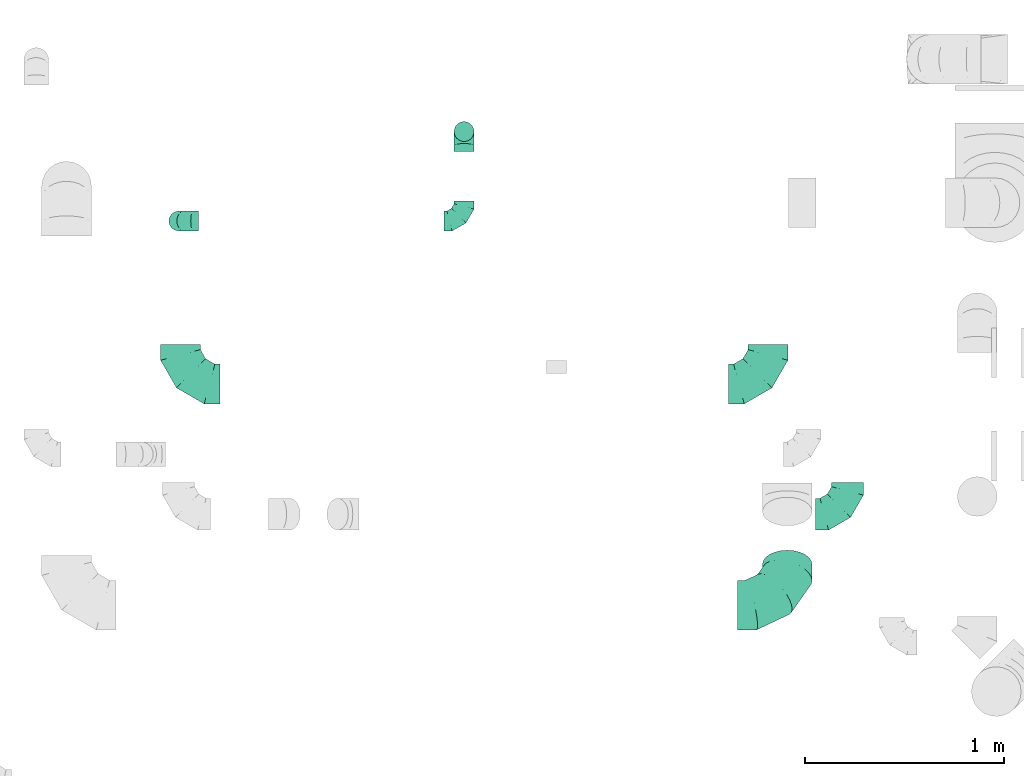
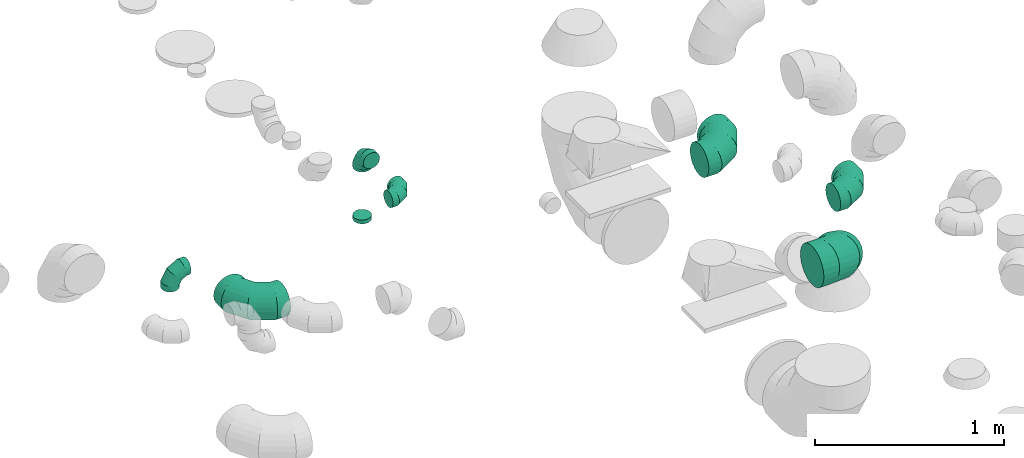
# One storey, part 42 of 59: 8 flow fittings.
"""IFC2X3 building model written with IfcOpenShell, lengths in millimetres."""

from ifc_helpers import new_model, entity, si_unit, converted_unit, derived_unit, direction, frame, origin, origin_2d_with_axis, place, context, subcontext, project, spatial, circle, extrude, faceted_brep, source, transform, mapped, material, type_object, type_shapes, element, save


model = new_model("IFC2X3")

# Units and contexts
model_context = context("Model", 3, precision=0.01, world=origin(), true_north=direction((6.12303176911189e-17, 1.0)))
body_context = subcontext(model_context, "Body", "Model", "MODEL_VIEW")
ifc_project = project(units=[si_unit("LENGTHUNIT", "METRE", prefix="MILLI"), si_unit("AREAUNIT", "SQUARE_METRE"), si_unit("VOLUMEUNIT", "CUBIC_METRE"), converted_unit("PLANEANGLEUNIT", "DEGREE", entity("IfcRatioMeasure", 0.0174532925199433), si_unit("PLANEANGLEUNIT", "RADIAN"), dimensions=[0, 0, 0, 0, 0, 0, 0]), si_unit("MASSUNIT", "GRAM", prefix="KILO"), derived_unit("MASSDENSITYUNIT", [(si_unit("MASSUNIT", "GRAM", prefix="KILO"), 1), (si_unit("LENGTHUNIT", "METRE"), -3)]), derived_unit("MOMENTOFINERTIAUNIT", [(si_unit("LENGTHUNIT", "METRE"), 4)]), si_unit("TIMEUNIT", "SECOND"), si_unit("FREQUENCYUNIT", "HERTZ"), si_unit("THERMODYNAMICTEMPERATUREUNIT", "DEGREE_CELSIUS"), derived_unit("THERMALTRANSMITTANCEUNIT", [(si_unit("MASSUNIT", "GRAM", prefix="KILO"), 1), (si_unit("THERMODYNAMICTEMPERATUREUNIT", "KELVIN"), -1), (si_unit("TIMEUNIT", "SECOND"), -3)]), derived_unit("VOLUMETRICFLOWRATEUNIT", [(si_unit("LENGTHUNIT", "METRE"), 3), (si_unit("TIMEUNIT", "SECOND"), -1)]), derived_unit("MASSFLOWRATEUNIT", [(si_unit("MASSUNIT", "GRAM", prefix="KILO"), 1), (si_unit("TIMEUNIT", "SECOND"), -1)]), derived_unit("ROTATIONALFREQUENCYUNIT", [(si_unit("TIMEUNIT", "SECOND"), -1)]), si_unit("ELECTRICCURRENTUNIT", "AMPERE"), si_unit("ELECTRICVOLTAGEUNIT", "VOLT"), si_unit("POWERUNIT", "WATT"), si_unit("FORCEUNIT", "NEWTON", prefix="KILO"), si_unit("ILLUMINANCEUNIT", "LUX"), si_unit("LUMINOUSFLUXUNIT", "LUMEN"), si_unit("LUMINOUSINTENSITYUNIT", "CANDELA"), derived_unit("USERDEFINED", [(si_unit("MASSUNIT", "GRAM", prefix="KILO"), -1), (si_unit("LENGTHUNIT", "METRE"), -2), (si_unit("TIMEUNIT", "SECOND"), 3), (si_unit("LUMINOUSFLUXUNIT", "LUMEN"), 1)]), derived_unit("LINEARVELOCITYUNIT", [(si_unit("LENGTHUNIT", "METRE"), 1), (si_unit("TIMEUNIT", "SECOND"), -1)]), si_unit("PRESSUREUNIT", "PASCAL"), derived_unit("USERDEFINED", [(si_unit("LENGTHUNIT", "METRE"), -2), (si_unit("MASSUNIT", "GRAM", prefix="KILO"), 1), (si_unit("TIMEUNIT", "SECOND"), -2)]), derived_unit("LINEARFORCEUNIT", [(si_unit("MASSUNIT", "GRAM", prefix="KILO"), 1), (si_unit("LENGTHUNIT", "METRE"), 1), (si_unit("TIMEUNIT", "SECOND"), -2), (si_unit("LENGTHUNIT", "METRE"), -1)]), derived_unit("PLANARFORCEUNIT", [(si_unit("MASSUNIT", "GRAM", prefix="KILO"), 1), (si_unit("LENGTHUNIT", "METRE"), 1), (si_unit("TIMEUNIT", "SECOND"), -2), (si_unit("LENGTHUNIT", "METRE"), -2)])], contexts=[model_context])

# Site, building, storey
site_placement = place(None, origin())
site = spatial("IfcSite", under=ifc_project, at=site_placement, CompositionType="ELEMENT")
building_placement = place(site_placement, origin())
building = spatial("IfcBuilding", under=site, at=building_placement, CompositionType="ELEMENT")
storey_placement = place(building_placement, frame((0.0, 0.0, 28200.0)))
storey = spatial("IfcBuildingStorey", under=building, at=storey_placement, CompositionType="ELEMENT", Elevation=28200.0)

# Flow fittings
ifc_material = material()
duct_fitting_type_1 = type_object("IfcDuctFittingType", PredefinedType="NOTDEFINED", material=ifc_material)
shared_shape_1 = source(origin(), body_context, "Body", "SweptSolid", [
    extrude(circle(Radius=49.9999999999997, at=origin_2d_with_axis()), frame((0.0, 0.0, 0.0), z_axis=(1.0, 0.0, 0.0), x_axis=(0.0, 1.0, 0.0)), (0.0, 0.0, 1.0), 25.0000000000018),
])
type_shapes(duct_fitting_type_1, [shared_shape_1])
flow_fitting_1_placement = place(storey_placement, frame((70040.54, 11618.54, 2740.0), z_axis=(0.0, -1.0, 0.0), x_axis=(0.0, 0.0, -1.0)))
element("IfcFlowFitting", 1, at=flow_fitting_1_placement, inside=storey, type_object=duct_fitting_type_1, material=ifc_material, context=body_context, shape_type="MappedRepresentation", body=[
    mapped(shared_shape_1, transform((0.0, 0.0, 0.0), scale=1.0)),
])
duct_fitting_type_2 = type_object("IfcDuctFittingType", PredefinedType="NOTDEFINED", material=ifc_material)
shared_shape_2 = source(origin(), body_context, "Body", "Brep", [
    faceted_brep([(-160.0, 0.0, -80.0), (-160.0, -20.71, -77.27), (-160.0, -40.0, -69.28), (-160.0, -56.57, -56.57), (-160.0, -69.28, -40.0), (-160.0, -77.27, -20.71), (-160.0, -80.0, 0.0), (-160.0, -77.27, 20.71), (-160.0, -69.28, 40.0), (-160.0, -56.57, 56.57), (-160.0, -40.0, 69.28), (-160.0, -20.71, 77.27), (-160.0, 0.0, 80.0), (-160.0, 20.71, 77.27), (-160.0, 40.0, 69.28), (-160.0, 56.57, 56.57), (-160.0, 69.28, 40.0), (-160.0, 77.27, 20.71), (-160.0, 80.0, 0.0), (-160.0, 77.27, -20.71), (-160.0, 69.28, -40.0), (-160.0, 56.57, -56.57), (-160.0, 40.0, -69.28), (-160.0, 20.71, -77.27), (-122.68, 20.71, 77.27), (-127.85, 40.0, 69.28), (-117.13, 0.0, 80.0), (-132.29, 56.57, 56.57), (-137.83, 77.27, 20.71), (-138.56, 80.0, 0.0), (-135.69, 69.28, 40.0), (-135.69, 69.28, -40.0), (-132.29, 56.57, -56.57), (-137.83, 77.27, -20.71), (-122.68, 20.71, -77.27), (-117.13, 0.0, -80.0), (-127.85, 40.0, -69.28), (-111.58, -20.71, -77.27), (-106.41, -40.0, -69.28), (-101.97, -56.57, -56.57), (-98.56, -69.28, -40.0), (-96.42, -77.27, -20.71), (-95.69, -80.0, 0.0), (-96.42, -77.27, 20.71), (-98.56, -69.28, 40.0), (-101.97, -56.57, 56.57), (-106.41, -40.0, 69.28), (-111.58, -20.71, 77.27), (-58.03, 58.03, 77.27), (-72.15, 72.15, 69.28), (-42.87, 42.87, 80.0), (-84.28, 84.28, 56.57), (-93.59, 93.59, 40.0), (-99.44, 99.44, 20.71), (-101.44, 101.44, 0.0), (-99.44, 99.44, -20.71), (-93.59, 93.59, -40.0), (-84.28, 84.28, -56.57), (-58.03, 58.03, -77.27), (-42.87, 42.87, -80.0), (-72.15, 72.15, -69.28), (-27.71, 27.71, -77.27), (-13.59, 13.59, -69.28), (-1.46, 1.46, -56.57), (7.85, -7.85, -40.0), (13.7, -13.7, -20.71), (15.69, -15.69, 0.0), (13.7, -13.7, 20.71), (7.85, -7.85, 40.0), (-1.46, 1.46, 56.57), (-13.59, 13.59, 69.28), (-27.71, 27.71, 77.27), (-20.71, 122.68, 77.27), (-40.0, 127.85, 69.28), (0.0, 117.13, 80.0), (-56.57, 132.29, 56.57), (-69.28, 135.69, 40.0), (-77.27, 137.83, 20.71), (-80.0, 138.56, 0.0), (-77.27, 137.83, -20.71), (-69.28, 135.69, -40.0), (-56.57, 132.29, -56.57), (-20.71, 122.68, -77.27), (0.0, 117.13, -80.0), (-40.0, 127.85, -69.28), (20.71, 111.58, -77.27), (40.0, 106.41, -69.28), (56.57, 101.97, -56.57), (69.28, 98.56, -40.0), (77.27, 96.42, -20.71), (80.0, 95.69, 0.0), (77.27, 96.42, 20.71), (69.28, 98.56, 40.0), (56.57, 101.97, 56.57), (40.0, 106.41, 69.28), (20.71, 111.58, 77.27), (-20.71, 160.0, -77.27), (-40.0, 160.0, -69.28), (-56.57, 160.0, -56.57), (-69.28, 160.0, -40.0), (-77.27, 160.0, -20.71), (-80.0, 160.0, 0.0), (-77.27, 160.0, 20.71), (-69.28, 160.0, 40.0), (-56.57, 160.0, 56.57), (-40.0, 160.0, 69.28), (-20.71, 160.0, 77.27), (0.0, 160.0, 80.0), (20.71, 160.0, 77.27), (40.0, 160.0, 69.28), (56.57, 160.0, 56.57), (69.28, 160.0, 40.0), (77.27, 160.0, 20.71), (80.0, 160.0, 0.0), (77.27, 160.0, -20.71), (69.28, 160.0, -40.0), (56.57, 160.0, -56.57), (40.0, 160.0, -69.28), (20.71, 160.0, -77.27), (0.0, 160.0, -80.0)], [[[0, 1, 2, 3, 4, 5, 6, 7, 8, 9, 10, 11, 12, 13, 14, 15, 16, 17, 18, 19, 20, 21, 22, 23]], [[24, 25, 14, 13]], [[26, 24, 13, 12]], [[14, 25, 27, 15]], [[28, 29, 18, 17]], [[30, 28, 17, 16]], [[15, 27, 30, 16]], [[20, 31, 32, 21]], [[33, 31, 20, 19]], [[18, 29, 33, 19]], [[34, 35, 0, 23]], [[36, 34, 23, 22]], [[32, 36, 22, 21]], [[1, 0, 35, 37]], [[2, 1, 37, 38]], [[3, 2, 38, 39]], [[5, 4, 40, 41]], [[6, 5, 41, 42]], [[39, 40, 4, 3]], [[6, 42, 43, 7]], [[7, 43, 44, 8]], [[8, 44, 45, 9]], [[9, 45, 46, 10]], [[10, 46, 47, 11]], [[26, 12, 11, 47]], [[48, 49, 25, 24]], [[50, 48, 24, 26]], [[27, 25, 49, 51]], [[52, 53, 28, 30]], [[51, 52, 30, 27]], [[29, 28, 53, 54]], [[55, 56, 31, 33]], [[54, 55, 33, 29]], [[32, 31, 56, 57]], [[58, 59, 35, 34]], [[60, 58, 34, 36]], [[57, 60, 36, 32]], [[37, 35, 59, 61]], [[38, 37, 61, 62]], [[39, 38, 62, 63]], [[41, 40, 64, 65]], [[42, 41, 65, 66]], [[63, 64, 40, 39]], [[43, 42, 66, 67]], [[44, 43, 67, 68]], [[68, 69, 45, 44]], [[46, 45, 69, 70]], [[47, 46, 70, 71]], [[26, 47, 71, 50]], [[72, 73, 49, 48]], [[74, 72, 48, 50]], [[51, 49, 73, 75]], [[76, 77, 53, 52]], [[75, 76, 52, 51]], [[54, 53, 77, 78]], [[79, 80, 56, 55]], [[78, 79, 55, 54]], [[57, 56, 80, 81]], [[82, 83, 59, 58]], [[84, 82, 58, 60]], [[81, 84, 60, 57]], [[61, 59, 83, 85]], [[62, 61, 85, 86]], [[63, 62, 86, 87]], [[65, 64, 88, 89]], [[66, 65, 89, 90]], [[87, 88, 64, 63]], [[67, 66, 90, 91]], [[68, 67, 91, 92]], [[92, 93, 69, 68]], [[70, 69, 93, 94]], [[71, 70, 94, 95]], [[50, 71, 95, 74]], [[96, 97, 98, 99, 100, 101, 102, 103, 104, 105, 106, 107, 108, 109, 110, 111, 112, 113, 114, 115, 116, 117, 118, 119]], [[72, 74, 107, 106]], [[73, 72, 106, 105]], [[75, 73, 105, 104]], [[77, 76, 103, 102]], [[78, 77, 102, 101]], [[75, 104, 103, 76]], [[78, 101, 100, 79]], [[79, 100, 99, 80]], [[80, 99, 98, 81]], [[84, 97, 96, 82]], [[82, 96, 119, 83]], [[84, 81, 98, 97]], [[118, 117, 86, 85]], [[119, 118, 85, 83]], [[116, 87, 86, 117]], [[88, 115, 114, 89]], [[89, 114, 113, 90]], [[115, 88, 87, 116]], [[112, 111, 92, 91]], [[113, 112, 91, 90]], [[111, 110, 93, 92]], [[95, 94, 109, 108]], [[74, 95, 108, 107]], [[110, 109, 94, 93]]]),
])
type_shapes(duct_fitting_type_2, [shared_shape_2])
flow_fitting_2_placement = place(storey_placement, frame((71970.11, 9693.42, 3400.0)))
element("IfcFlowFitting", 2, at=flow_fitting_2_placement, inside=storey, type_object=duct_fitting_type_2, material=ifc_material, context=body_context, shape_type="MappedRepresentation", body=[
    mapped(shared_shape_2, transform((0.0, 0.0, 0.0), scale=1.0)),
])
duct_fitting_type_3 = type_object("IfcDuctFittingType", PredefinedType="NOTDEFINED", material=ifc_material)
shared_shape_3 = source(origin(), body_context, "Body", "Brep", [
    faceted_brep([(-100.0, 0.0, -50.0), (-100.0, -12.94, -48.3), (-100.0, -25.0, -43.3), (-100.0, -35.36, -35.36), (-100.0, -43.3, -25.0), (-100.0, -48.3, -12.94), (-100.0, -50.0, 0.0), (-100.0, -48.3, 12.94), (-100.0, -43.3, 25.0), (-100.0, -35.36, 35.36), (-100.0, -25.0, 43.3), (-100.0, -12.94, 48.3), (-100.0, 0.0, 50.0), (-100.0, 12.94, 48.3), (-100.0, 25.0, 43.3), (-100.0, 35.36, 35.36), (-100.0, 43.3, 25.0), (-100.0, 48.3, 12.94), (-100.0, 50.0, 0.0), (-100.0, 48.3, -12.94), (-100.0, 43.3, -25.0), (-100.0, 35.36, -35.36), (-100.0, 25.0, -43.3), (-100.0, 12.94, -48.3), (-76.67, 12.94, 48.3), (-79.9, 25.0, 43.3), (-73.21, 0.0, 50.0), (-82.68, 35.36, 35.36), (-86.15, 48.3, 12.94), (-86.6, 50.0, 0.0), (-84.81, 43.3, 25.0), (-84.81, 43.3, -25.0), (-82.68, 35.36, -35.36), (-86.15, 48.3, -12.94), (-76.67, 12.94, -48.3), (-73.21, 0.0, -50.0), (-79.9, 25.0, -43.3), (-69.74, -12.94, -48.3), (-66.51, -25.0, -43.3), (-63.73, -35.36, -35.36), (-61.6, -43.3, -25.0), (-60.26, -48.3, -12.94), (-59.81, -50.0, 0.0), (-60.26, -48.3, 12.94), (-61.6, -43.3, 25.0), (-63.73, -35.36, 35.36), (-66.51, -25.0, 43.3), (-69.74, -12.94, 48.3), (-36.27, 36.27, 48.3), (-45.1, 45.1, 43.3), (-26.79, 26.79, 50.0), (-52.68, 52.68, 35.36), (-58.49, 58.49, 25.0), (-62.15, 62.15, 12.94), (-63.4, 63.4, 0.0), (-62.15, 62.15, -12.94), (-58.49, 58.49, -25.0), (-52.68, 52.68, -35.36), (-36.27, 36.27, -48.3), (-26.79, 26.79, -50.0), (-45.1, 45.1, -43.3), (-17.32, 17.32, -48.3), (-8.49, 8.49, -43.3), (-0.91, 0.91, -35.36), (4.9, -4.9, -25.0), (8.56, -8.56, -12.94), (9.81, -9.81, 0.0), (8.56, -8.56, 12.94), (4.9, -4.9, 25.0), (-0.91, 0.91, 35.36), (-8.49, 8.49, 43.3), (-17.32, 17.32, 48.3), (-12.94, 76.67, 48.3), (-25.0, 79.9, 43.3), (0.0, 73.21, 50.0), (-35.36, 82.68, 35.36), (-43.3, 84.81, 25.0), (-48.3, 86.15, 12.94), (-50.0, 86.6, 0.0), (-48.3, 86.15, -12.94), (-43.3, 84.81, -25.0), (-35.36, 82.68, -35.36), (-12.94, 76.67, -48.3), (0.0, 73.21, -50.0), (-25.0, 79.9, -43.3), (12.94, 69.74, -48.3), (25.0, 66.51, -43.3), (35.36, 63.73, -35.36), (43.3, 61.6, -25.0), (48.3, 60.26, -12.94), (50.0, 59.81, 0.0), (48.3, 60.26, 12.94), (43.3, 61.6, 25.0), (35.36, 63.73, 35.36), (25.0, 66.51, 43.3), (12.94, 69.74, 48.3), (-12.94, 100.0, -48.3), (-25.0, 100.0, -43.3), (-35.36, 100.0, -35.36), (-43.3, 100.0, -25.0), (-48.3, 100.0, -12.94), (-50.0, 100.0, 0.0), (-48.3, 100.0, 12.94), (-43.3, 100.0, 25.0), (-35.36, 100.0, 35.36), (-25.0, 100.0, 43.3), (-12.94, 100.0, 48.3), (0.0, 100.0, 50.0), (12.94, 100.0, 48.3), (25.0, 100.0, 43.3), (35.36, 100.0, 35.36), (43.3, 100.0, 25.0), (48.3, 100.0, 12.94), (50.0, 100.0, 0.0), (48.3, 100.0, -12.94), (43.3, 100.0, -25.0), (35.36, 100.0, -35.36), (25.0, 100.0, -43.3), (12.94, 100.0, -48.3), (0.0, 100.0, -50.0)], [[[0, 1, 2, 3, 4, 5, 6, 7, 8, 9, 10, 11, 12, 13, 14, 15, 16, 17, 18, 19, 20, 21, 22, 23]], [[24, 25, 14, 13]], [[26, 24, 13, 12]], [[14, 25, 27, 15]], [[28, 29, 18, 17]], [[30, 28, 17, 16]], [[15, 27, 30, 16]], [[20, 31, 32, 21]], [[33, 31, 20, 19]], [[18, 29, 33, 19]], [[34, 35, 0, 23]], [[36, 34, 23, 22]], [[32, 36, 22, 21]], [[2, 1, 37, 38]], [[3, 2, 38, 39]], [[0, 35, 37, 1]], [[5, 4, 40, 41]], [[6, 5, 41, 42]], [[3, 39, 40, 4]], [[6, 42, 43, 7]], [[7, 43, 44, 8]], [[8, 44, 45, 9]], [[10, 46, 47, 11]], [[11, 47, 26, 12]], [[10, 9, 45, 46]], [[48, 49, 25, 24]], [[50, 48, 24, 26]], [[27, 25, 49, 51]], [[52, 53, 28, 30]], [[51, 52, 30, 27]], [[29, 28, 53, 54]], [[55, 56, 31, 33]], [[54, 55, 33, 29]], [[57, 32, 31, 56]], [[58, 59, 35, 34]], [[60, 58, 34, 36]], [[57, 60, 36, 32]], [[37, 35, 59, 61]], [[38, 37, 61, 62]], [[39, 38, 62, 63]], [[41, 40, 64, 65]], [[42, 41, 65, 66]], [[63, 64, 40, 39]], [[43, 42, 66, 67]], [[44, 43, 67, 68]], [[68, 69, 45, 44]], [[46, 45, 69, 70]], [[47, 46, 70, 71]], [[26, 47, 71, 50]], [[72, 73, 49, 48]], [[74, 72, 48, 50]], [[51, 49, 73, 75]], [[76, 77, 53, 52]], [[75, 76, 52, 51]], [[54, 53, 77, 78]], [[79, 80, 56, 55]], [[78, 79, 55, 54]], [[81, 57, 56, 80]], [[82, 83, 59, 58]], [[84, 82, 58, 60]], [[81, 84, 60, 57]], [[61, 59, 83, 85]], [[62, 61, 85, 86]], [[63, 62, 86, 87]], [[65, 64, 88, 89]], [[66, 65, 89, 90]], [[87, 88, 64, 63]], [[67, 66, 90, 91]], [[68, 67, 91, 92]], [[92, 93, 69, 68]], [[70, 69, 93, 94]], [[71, 70, 94, 95]], [[50, 71, 95, 74]], [[96, 97, 98, 99, 100, 101, 102, 103, 104, 105, 106, 107, 108, 109, 110, 111, 112, 113, 114, 115, 116, 117, 118, 119]], [[72, 74, 107, 106]], [[73, 72, 106, 105]], [[75, 73, 105, 104]], [[77, 76, 103, 102]], [[78, 77, 102, 101]], [[75, 104, 103, 76]], [[78, 101, 100, 79]], [[79, 100, 99, 80]], [[80, 99, 98, 81]], [[96, 119, 83, 82]], [[97, 96, 82, 84]], [[84, 81, 98, 97]], [[83, 119, 118, 85]], [[85, 118, 117, 86]], [[86, 117, 116, 87]], [[88, 115, 114, 89]], [[89, 114, 113, 90]], [[87, 116, 115, 88]], [[91, 90, 113, 112]], [[92, 91, 112, 111]], [[93, 92, 111, 110]], [[95, 94, 109, 108]], [[74, 95, 108, 107]], [[110, 109, 94, 93]]]),
])
type_shapes(duct_fitting_type_3, [shared_shape_3])
flow_fitting_3_placement = place(storey_placement, frame((70040.54, 11168.54, 3150.0)))
element("IfcFlowFitting", 3, at=flow_fitting_3_placement, inside=storey, type_object=duct_fitting_type_3, material=ifc_material, context=body_context, shape_type="MappedRepresentation", body=[
    mapped(shared_shape_3, transform((0.0, 0.0, 0.0), scale=1.0)),
])
for number, where, z_axis, x_axis in (
    (4, (70040.54, 11618.54, 3150.0), (-1.0, 0.0, 0.0), (0.0, 1.0, 0.0)),
    (5, (68605.54, 11168.54, 3150.0), (0.0, -1.0, 0.0), (-1.0, 0.0, 0.0)),
):
    element("IfcFlowFitting", number, at=place(storey_placement, frame(where, z_axis=z_axis, x_axis=x_axis)), inside=storey, type_object=duct_fitting_type_3, material=ifc_material, context=body_context, shape_type="MappedRepresentation", body=[
        mapped(shared_shape_3, transform((0.0, 0.0, 0.0), scale=1.0)),
    ])
duct_fitting_type_4 = type_object("IfcDuctFittingType", PredefinedType="NOTDEFINED", material=ifc_material)
shared_shape_4 = source(origin(), body_context, "Body", "Brep", [
    faceted_brep([(-250.0, 0.0, -125.0), (-250.0, -32.35, -120.74), (-250.0, -62.5, -108.25), (-250.0, -88.39, -88.39), (-250.0, -108.25, -62.5), (-250.0, -120.74, -32.35), (-250.0, -125.0, 0.0), (-250.0, -120.74, 32.35), (-250.0, -108.25, 62.5), (-250.0, -88.39, 88.39), (-250.0, -62.5, 108.25), (-250.0, -32.35, 120.74), (-250.0, 0.0, 125.0), (-250.0, 32.35, 120.74), (-250.0, 62.5, 108.25), (-250.0, 88.39, 88.39), (-250.0, 108.25, 62.5), (-250.0, 120.74, 32.35), (-250.0, 125.0, 0.0), (-250.0, 120.74, -32.35), (-250.0, 108.25, -62.5), (-250.0, 88.39, -88.39), (-250.0, 62.5, -108.25), (-250.0, 32.35, -120.74), (-191.68, 32.35, 120.74), (-199.76, 62.5, 108.25), (-183.01, 0.0, 125.0), (-206.7, 88.39, 88.39), (-215.37, 120.74, 32.35), (-216.51, 125.0, 0.0), (-212.02, 108.25, 62.5), (-212.02, 108.25, -62.5), (-206.7, 88.39, -88.39), (-215.37, 120.74, -32.35), (-191.68, 32.35, -120.74), (-183.01, 0.0, -125.0), (-199.76, 62.5, -108.25), (-174.34, -32.35, -120.74), (-166.27, -62.5, -108.25), (-159.33, -88.39, -88.39), (-154.01, -108.25, -62.5), (-150.66, -120.74, -32.35), (-149.52, -125.0, 0.0), (-150.66, -120.74, 32.35), (-154.01, -108.25, 62.5), (-159.33, -88.39, 88.39), (-166.27, -62.5, 108.25), (-174.34, -32.35, 120.74), (-90.67, 90.67, 120.74), (-112.74, 112.74, 108.25), (-66.99, 66.99, 125.0), (-131.69, 131.69, 88.39), (-146.23, 146.23, 62.5), (-155.38, 155.38, 32.35), (-158.49, 158.49, 0.0), (-155.38, 155.38, -32.35), (-146.23, 146.23, -62.5), (-131.69, 131.69, -88.39), (-90.67, 90.67, -120.74), (-66.99, 66.99, -125.0), (-112.74, 112.74, -108.25), (-43.3, 43.3, -120.74), (-21.23, 21.23, -108.25), (-2.28, 2.28, -88.39), (12.26, -12.26, -62.5), (21.4, -21.4, -32.35), (24.52, -24.52, 0.0), (21.4, -21.4, 32.35), (12.26, -12.26, 62.5), (-2.28, 2.28, 88.39), (-21.23, 21.23, 108.25), (-43.3, 43.3, 120.74), (-32.35, 191.68, 120.74), (-62.5, 199.76, 108.25), (0.0, 183.01, 125.0), (-88.39, 206.7, 88.39), (-108.25, 212.02, 62.5), (-120.74, 215.37, 32.35), (-125.0, 216.51, 0.0), (-120.74, 215.37, -32.35), (-108.25, 212.02, -62.5), (-88.39, 206.7, -88.39), (-32.35, 191.68, -120.74), (0.0, 183.01, -125.0), (-62.5, 199.76, -108.25), (32.35, 174.34, -120.74), (62.5, 166.27, -108.25), (88.39, 159.33, -88.39), (108.25, 154.01, -62.5), (120.74, 150.66, -32.35), (125.0, 149.52, 0.0), (120.74, 150.66, 32.35), (108.25, 154.01, 62.5), (88.39, 159.33, 88.39), (62.5, 166.27, 108.25), (32.35, 174.34, 120.74), (-32.35, 250.0, -120.74), (-62.5, 250.0, -108.25), (-88.39, 250.0, -88.39), (-108.25, 250.0, -62.5), (-120.74, 250.0, -32.35), (-125.0, 250.0, 0.0), (-120.74, 250.0, 32.35), (-108.25, 250.0, 62.5), (-88.39, 250.0, 88.39), (-62.5, 250.0, 108.25), (-32.35, 250.0, 120.74), (0.0, 250.0, 125.0), (32.35, 250.0, 120.74), (62.5, 250.0, 108.25), (88.39, 250.0, 88.39), (108.25, 250.0, 62.5), (120.74, 250.0, 32.35), (125.0, 250.0, 0.0), (120.74, 250.0, -32.35), (108.25, 250.0, -62.5), (88.39, 250.0, -88.39), (62.5, 250.0, -108.25), (32.35, 250.0, -120.74), (0.0, 250.0, -125.0)], [[[0, 1, 2, 3, 4, 5, 6, 7, 8, 9, 10, 11, 12, 13, 14, 15, 16, 17, 18, 19, 20, 21, 22, 23]], [[24, 25, 14, 13]], [[26, 24, 13, 12]], [[14, 25, 27, 15]], [[28, 29, 18, 17]], [[30, 28, 17, 16]], [[15, 27, 30, 16]], [[20, 31, 32, 21]], [[33, 31, 20, 19]], [[18, 29, 33, 19]], [[34, 35, 0, 23]], [[36, 34, 23, 22]], [[21, 32, 36, 22]], [[1, 0, 35, 37]], [[2, 1, 37, 38]], [[38, 39, 3, 2]], [[5, 4, 40, 41]], [[6, 5, 41, 42]], [[39, 40, 4, 3]], [[6, 42, 43, 7]], [[7, 43, 44, 8]], [[8, 44, 45, 9]], [[9, 45, 46, 10]], [[10, 46, 47, 11]], [[26, 12, 11, 47]], [[48, 49, 25, 24]], [[50, 48, 24, 26]], [[27, 25, 49, 51]], [[52, 53, 28, 30]], [[51, 52, 30, 27]], [[29, 28, 53, 54]], [[55, 56, 31, 33]], [[54, 55, 33, 29]], [[32, 31, 56, 57]], [[58, 59, 35, 34]], [[60, 58, 34, 36]], [[57, 60, 36, 32]], [[37, 35, 59, 61]], [[38, 37, 61, 62]], [[39, 38, 62, 63]], [[41, 40, 64, 65]], [[42, 41, 65, 66]], [[63, 64, 40, 39]], [[43, 42, 66, 67]], [[44, 43, 67, 68]], [[68, 69, 45, 44]], [[46, 45, 69, 70]], [[47, 46, 70, 71]], [[26, 47, 71, 50]], [[72, 73, 49, 48]], [[74, 72, 48, 50]], [[51, 49, 73, 75]], [[76, 77, 53, 52]], [[75, 76, 52, 51]], [[54, 53, 77, 78]], [[79, 80, 56, 55]], [[78, 79, 55, 54]], [[57, 56, 80, 81]], [[82, 83, 59, 58]], [[84, 82, 58, 60]], [[81, 84, 60, 57]], [[61, 59, 83, 85]], [[62, 61, 85, 86]], [[63, 62, 86, 87]], [[65, 64, 88, 89]], [[66, 65, 89, 90]], [[87, 88, 64, 63]], [[67, 66, 90, 91]], [[68, 67, 91, 92]], [[92, 93, 69, 68]], [[70, 69, 93, 94]], [[71, 70, 94, 95]], [[50, 71, 95, 74]], [[96, 97, 98, 99, 100, 101, 102, 103, 104, 105, 106, 107, 108, 109, 110, 111, 112, 113, 114, 115, 116, 117, 118, 119]], [[72, 74, 107, 106]], [[73, 72, 106, 105]], [[75, 73, 105, 104]], [[77, 76, 103, 102]], [[78, 77, 102, 101]], [[75, 104, 103, 76]], [[78, 101, 100, 79]], [[79, 100, 99, 80]], [[80, 99, 98, 81]], [[84, 97, 96, 82]], [[82, 96, 119, 83]], [[84, 81, 98, 97]], [[83, 119, 118, 85]], [[85, 118, 117, 86]], [[116, 87, 86, 117]], [[88, 115, 114, 89]], [[89, 114, 113, 90]], [[115, 88, 87, 116]], [[91, 90, 113, 112]], [[92, 91, 112, 111]], [[111, 110, 93, 92]], [[95, 94, 109, 108]], [[74, 95, 108, 107]], [[110, 109, 94, 93]]]),
])
type_shapes(duct_fitting_type_4, [shared_shape_4])
flow_fitting_4_placement = place(storey_placement, frame((71666.81, 9235.86, 3375.0), z_axis=(0.0, 0.573576436351062, 0.81915204428898), x_axis=(1.0, 0.0, 0.0)))
element("IfcFlowFitting", 6, at=flow_fitting_4_placement, inside=storey, type_object=duct_fitting_type_4, material=ifc_material, context=body_context, shape_type="MappedRepresentation", body=[
    mapped(shared_shape_4, transform((0.0, 0.0, 0.0), scale=1.0)),
])
duct_fitting_type_5 = type_object("IfcDuctFittingType", PredefinedType="NOTDEFINED", material=ifc_material)
shared_shape_5 = source(origin(), body_context, "Body", "Brep", [
    faceted_brep([(-200.0, 0.0, -100.0), (-200.0, -25.88, -96.59), (-200.0, -50.0, -86.6), (-200.0, -70.71, -70.71), (-200.0, -86.6, -50.0), (-200.0, -96.59, -25.88), (-200.0, -100.0, 0.0), (-200.0, -96.59, 25.88), (-200.0, -86.6, 50.0), (-200.0, -70.71, 70.71), (-200.0, -50.0, 86.6), (-200.0, -25.88, 96.59), (-200.0, 0.0, 100.0), (-200.0, 25.88, 96.59), (-200.0, 50.0, 86.6), (-200.0, 70.71, 70.71), (-200.0, 86.6, 50.0), (-200.0, 96.59, 25.88), (-200.0, 100.0, 0.0), (-200.0, 96.59, -25.88), (-200.0, 86.6, -50.0), (-200.0, 70.71, -70.71), (-200.0, 50.0, -86.6), (-200.0, 25.88, -96.59), (-153.35, 25.88, 96.59), (-159.81, 50.0, 86.6), (-146.41, 0.0, 100.0), (-165.36, 70.71, 70.71), (-172.29, 96.59, 25.88), (-173.21, 100.0, 0.0), (-169.62, 86.6, 50.0), (-169.62, 86.6, -50.0), (-165.36, 70.71, -70.71), (-172.29, 96.59, -25.88), (-153.35, 25.88, -96.59), (-146.41, 0.0, -100.0), (-159.81, 50.0, -86.6), (-139.48, -25.88, -96.59), (-133.01, -50.0, -86.6), (-127.46, -70.71, -70.71), (-123.21, -86.6, -50.0), (-120.53, -96.59, -25.88), (-119.62, -100.0, 0.0), (-120.53, -96.59, 25.88), (-123.21, -86.6, 50.0), (-127.46, -70.71, 70.71), (-133.01, -50.0, 86.6), (-139.48, -25.88, 96.59), (-72.54, 72.54, 96.59), (-90.19, 90.19, 86.6), (-53.59, 53.59, 100.0), (-105.35, 105.35, 70.71), (-116.99, 116.99, 50.0), (-124.3, 124.3, 25.88), (-126.79, 126.79, 0.0), (-124.3, 124.3, -25.88), (-116.99, 116.99, -50.0), (-105.35, 105.35, -70.71), (-72.54, 72.54, -96.59), (-53.59, 53.59, -100.0), (-90.19, 90.19, -86.6), (-34.64, 34.64, -96.59), (-16.99, 16.99, -86.6), (-1.83, 1.83, -70.71), (9.81, -9.81, -50.0), (17.12, -17.12, -25.88), (19.62, -19.62, 0.0), (17.12, -17.12, 25.88), (9.81, -9.81, 50.0), (-1.83, 1.83, 70.71), (-16.99, 16.99, 86.6), (-34.64, 34.64, 96.59), (-25.88, 153.35, 96.59), (-50.0, 159.81, 86.6), (0.0, 146.41, 100.0), (-70.71, 165.36, 70.71), (-86.6, 169.62, 50.0), (-96.59, 172.29, 25.88), (-100.0, 173.21, 0.0), (-96.59, 172.29, -25.88), (-86.6, 169.62, -50.0), (-70.71, 165.36, -70.71), (-25.88, 153.35, -96.59), (0.0, 146.41, -100.0), (-50.0, 159.81, -86.6), (25.88, 139.48, -96.59), (50.0, 133.01, -86.6), (70.71, 127.46, -70.71), (86.6, 123.21, -50.0), (96.59, 120.53, -25.88), (100.0, 119.62, 0.0), (96.59, 120.53, 25.88), (86.6, 123.21, 50.0), (70.71, 127.46, 70.71), (50.0, 133.01, 86.6), (25.88, 139.48, 96.59), (-25.88, 200.0, -96.59), (-50.0, 200.0, -86.6), (-70.71, 200.0, -70.71), (-86.6, 200.0, -50.0), (-96.59, 200.0, -25.88), (-100.0, 200.0, 0.0), (-96.59, 200.0, 25.88), (-86.6, 200.0, 50.0), (-70.71, 200.0, 70.71), (-50.0, 200.0, 86.6), (-25.88, 200.0, 96.59), (0.0, 200.0, 100.0), (25.88, 200.0, 96.59), (50.0, 200.0, 86.6), (70.71, 200.0, 70.71), (86.6, 200.0, 50.0), (96.59, 200.0, 25.88), (100.0, 200.0, 0.0), (96.59, 200.0, -25.88), (86.6, 200.0, -50.0), (70.71, 200.0, -70.71), (50.0, 200.0, -86.6), (25.88, 200.0, -96.59), (0.0, 200.0, -100.0)], [[[0, 1, 2, 3, 4, 5, 6, 7, 8, 9, 10, 11, 12, 13, 14, 15, 16, 17, 18, 19, 20, 21, 22, 23]], [[24, 25, 14, 13]], [[26, 24, 13, 12]], [[14, 25, 27, 15]], [[28, 29, 18, 17]], [[30, 28, 17, 16]], [[15, 27, 30, 16]], [[20, 31, 32, 21]], [[33, 31, 20, 19]], [[18, 29, 33, 19]], [[34, 35, 0, 23]], [[36, 34, 23, 22]], [[32, 36, 22, 21]], [[1, 0, 35, 37]], [[2, 1, 37, 38]], [[38, 39, 3, 2]], [[5, 4, 40, 41]], [[6, 5, 41, 42]], [[39, 40, 4, 3]], [[6, 42, 43, 7]], [[7, 43, 44, 8]], [[8, 44, 45, 9]], [[9, 45, 46, 10]], [[10, 46, 47, 11]], [[26, 12, 11, 47]], [[48, 49, 25, 24]], [[50, 48, 24, 26]], [[27, 25, 49, 51]], [[52, 53, 28, 30]], [[51, 52, 30, 27]], [[29, 28, 53, 54]], [[55, 56, 31, 33]], [[54, 55, 33, 29]], [[32, 31, 56, 57]], [[58, 59, 35, 34]], [[60, 58, 34, 36]], [[57, 60, 36, 32]], [[37, 35, 59, 61]], [[38, 37, 61, 62]], [[39, 38, 62, 63]], [[41, 40, 64, 65]], [[42, 41, 65, 66]], [[63, 64, 40, 39]], [[43, 42, 66, 67]], [[44, 43, 67, 68]], [[68, 69, 45, 44]], [[46, 45, 69, 70]], [[47, 46, 70, 71]], [[26, 47, 71, 50]], [[72, 73, 49, 48]], [[74, 72, 48, 50]], [[51, 49, 73, 75]], [[76, 77, 53, 52]], [[75, 76, 52, 51]], [[54, 53, 77, 78]], [[79, 80, 56, 55]], [[78, 79, 55, 54]], [[57, 56, 80, 81]], [[82, 83, 59, 58]], [[84, 82, 58, 60]], [[81, 84, 60, 57]], [[61, 59, 83, 85]], [[62, 61, 85, 86]], [[63, 62, 86, 87]], [[65, 64, 88, 89]], [[66, 65, 89, 90]], [[87, 88, 64, 63]], [[67, 66, 90, 91]], [[68, 67, 91, 92]], [[92, 93, 69, 68]], [[70, 69, 93, 94]], [[71, 70, 94, 95]], [[50, 71, 95, 74]], [[96, 97, 98, 99, 100, 101, 102, 103, 104, 105, 106, 107, 108, 109, 110, 111, 112, 113, 114, 115, 116, 117, 118, 119]], [[72, 74, 107, 106]], [[73, 72, 106, 105]], [[75, 73, 105, 104]], [[102, 101, 78, 77]], [[103, 102, 77, 76]], [[75, 104, 103, 76]], [[78, 101, 100, 79]], [[79, 100, 99, 80]], [[80, 99, 98, 81]], [[84, 97, 96, 82]], [[82, 96, 119, 83]], [[84, 81, 98, 97]], [[118, 117, 86, 85]], [[119, 118, 85, 83]], [[116, 87, 86, 117]], [[88, 115, 114, 89]], [[89, 114, 113, 90]], [[115, 88, 87, 116]], [[91, 90, 113, 112]], [[92, 91, 112, 111]], [[111, 110, 93, 92]], [[95, 94, 109, 108]], [[74, 95, 108, 107]], [[110, 109, 94, 93]]]),
])
type_shapes(duct_fitting_type_5, [shared_shape_5])
flow_fitting_5_placement = place(storey_placement, frame((71570.11, 10348.42, 3400.0)))
element("IfcFlowFitting", 7, at=flow_fitting_5_placement, inside=storey, type_object=duct_fitting_type_5, material=ifc_material, context=body_context, shape_type="MappedRepresentation", body=[
    mapped(shared_shape_5, transform((0.0, 0.0, 0.0), scale=1.0)),
])
flow_fitting_6_placement = place(storey_placement, frame((68613.63, 10348.42, 3400.0), z_axis=(0.0, 0.0, 1.0), x_axis=(0.0, -1.0, 0.0)))
element("IfcFlowFitting", 8, at=flow_fitting_6_placement, inside=storey, type_object=duct_fitting_type_5, material=ifc_material, context=body_context, shape_type="MappedRepresentation", body=[
    mapped(shared_shape_5, transform((0.0, 0.0, 0.0), scale=1.0)),
])

save(model, "model.ifc")
